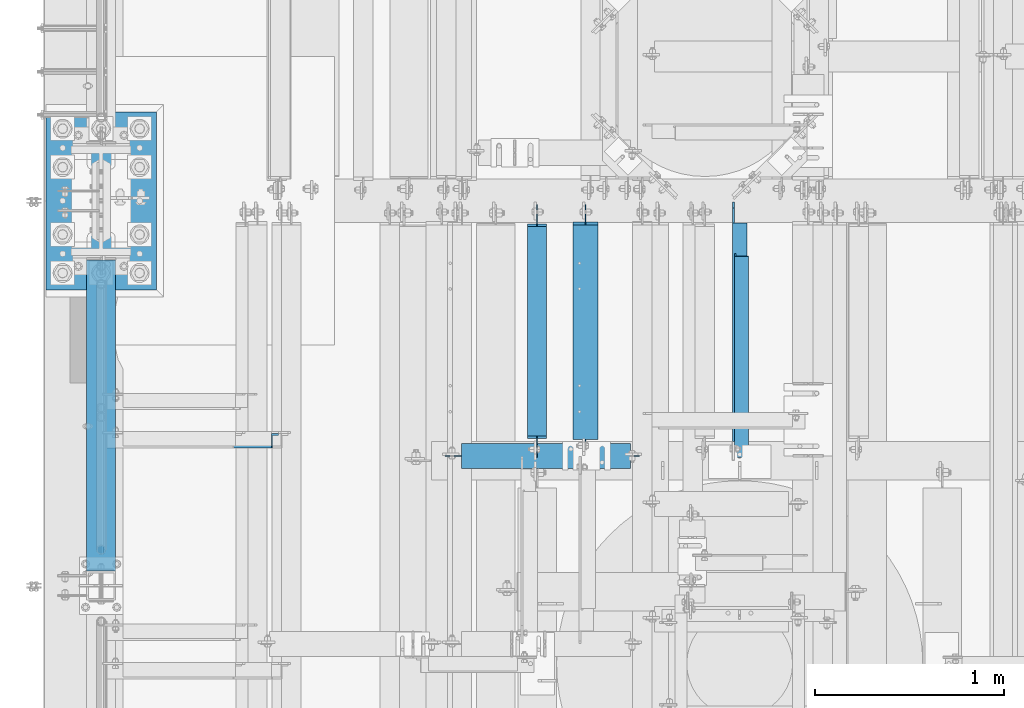
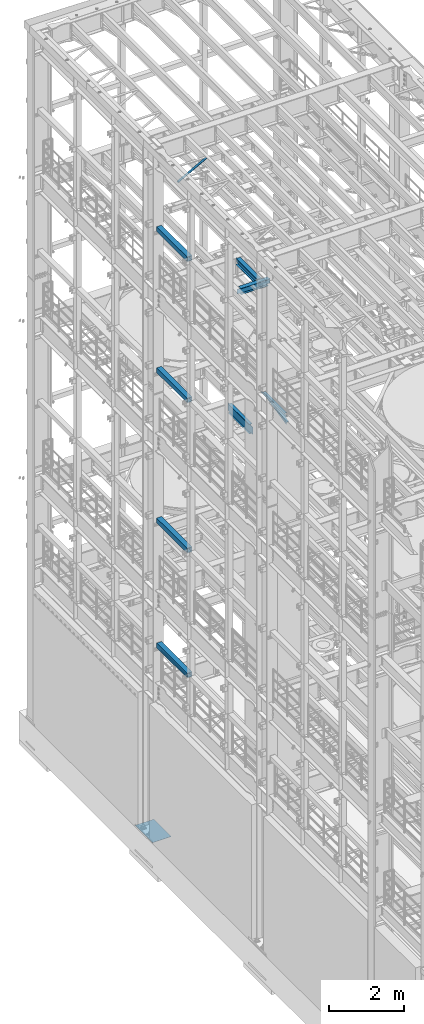
# One storey, part 1041 of 1876: 11 beams, 1 member, 12 elements without a shape of their own.
"""IFC2X3 building model written with IfcOpenShell, lengths in millimetres."""

from ifc_helpers import new_model, si_unit, frame, origin_with_axes, place, context, subcontext, project, spatial, faceted_brep, material, type_object, element, aggregate, save


model = new_model("IFC2X3")

# Units and contexts
model_context = context("Model", 3, precision=1e-05, world=origin_with_axes())
body_context = subcontext(model_context, "Body", "Model", "MODEL_VIEW")
ifc_project = project(units=[si_unit("LENGTHUNIT", "METRE", prefix="MILLI"), si_unit("AREAUNIT", "SQUARE_METRE"), si_unit("VOLUMEUNIT", "CUBIC_METRE"), si_unit("MASSUNIT", "GRAM", prefix="KILO"), si_unit("TIMEUNIT", "SECOND"), si_unit("PLANEANGLEUNIT", "RADIAN"), si_unit("SOLIDANGLEUNIT", "STERADIAN"), si_unit("THERMODYNAMICTEMPERATUREUNIT", "DEGREE_CELSIUS"), si_unit("LUMINOUSINTENSITYUNIT", "LUMEN")], contexts=[model_context])

# Site, building, storey
site_placement = place(None, origin_with_axes())
site = spatial("IfcSite", under=ifc_project, at=site_placement, CompositionType="ELEMENT")
building_placement = place(site_placement, origin_with_axes())
building = spatial("IfcBuilding", under=site, at=building_placement, Name="Undefined", CompositionType="ELEMENT")
storey_placement = place(building_placement, origin_with_axes())
storey = spatial("IfcBuildingStorey", under=building, at=storey_placement, Name="Undefined", CompositionType="ELEMENT", Elevation=0.0)

# Assembly, beam
assembly_1_placement = place(storey_placement, origin_with_axes())
assembly_1 = element("IfcElementAssembly", 1, at=assembly_1_placement, inside=storey, Name="RAIL", AssemblyPlace="NOTDEFINED", PredefinedType="RIGID_FRAME")
ifc_material_1 = material()
beam_type_1 = type_object("IfcBeamType", Name="PIPE1-1/2SCH40", PredefinedType="NOTDEFINED")
beam_1_placement = place(assembly_1_placement, frame((6.79847289575264e-10, 7204.0396633614, 6207.13724280096), z_axis=(0.0, 7.91400000045761e-06, -0.999999999968684), x_axis=(0.0, -0.999999999968684, -7.91400000071008e-06)))
beam_1 = element("IfcBeam", 2, at=beam_1_placement, type_object=beam_type_1, material=ifc_material_1, Name="RAIL", ObjectType="PIPE1-1/2SCH40", context=body_context, shape_type="Brep", body=[
    faceted_brep([(24.1297889306325, -20.4470000000001, 4.54747350886464e-12), (34.3533782626628, -17.7076214311801, 10.223500000001), (1416.58624781054, -17.7076214311801, 10.2235000002374), (1426.80965847928, -20.4470000000001, 2.42835085373372e-10), (41.8375650894295, -10.2235000000001, 17.7076214311801), (1409.10219177439, -10.2235000000001, 17.7076214314138), (44.5770000000002, 0.0, 20.4470000000001), (1406.3628371418, 0.0, 20.4470000002311), (41.8375650894295, 10.2235000000001, 17.7076214311801), (1409.10219177439, 10.2235000000001, 17.7076214314138), (34.3533782626628, 17.7076214311801, 10.223500000001), (1416.58624781054, 17.7076214311801, 10.2235000002374), (24.1297889306325, 20.4470000000001, 4.54747350886464e-12), (1426.80965847928, 20.4470000000001, 2.42835085373372e-10), (13.9061995986012, 17.7076214311801, -10.2234999999919), (1437.03306914802, 17.7076214311801, -10.2234999997499), (6.42201277183449, 10.2235000000001, -17.707621431171), (1444.51712518418, 10.2235000000001, -17.7076214309263), (3.68261026657001, 0.0, -20.4469999999901), (1447.25647981676, 0.0, -20.4469999997445), (6.42201277183449, -10.2235000000001, -17.707621431171), (1444.51712518418, -10.2235000000001, -17.7076214309263), (13.9061995986012, -17.7076214311801, -10.2234999999919), (1437.03306914802, -17.7076214311801, -10.2234999997499), (24.1297889306325, -24.1300000000001, 4.54747350886464e-12), (12.0646835077378, -20.8971929933186, -12.0649999999923), (1438.8745530573, -20.8971929933186, -12.0649999997486), (1426.80965847928, -24.1300000000001, 2.42835085373372e-10), (3.23241333950409, -12.0649999999996, -20.8971929933086), (1447.70666887637, -12.0649999999996, -20.8971929930613), (-0.000421915156039177, 0.0, -24.1299999999892), (1450.93944763532, 0.0, -24.1299999997409), (3.23241333950409, 12.0649999999996, -20.8971929933086), (1447.70666887637, 12.0649999999996, -20.8971929930613), (12.0646835077378, 20.8971929933186, -12.0649999999923), (1438.8745530573, 20.8971929933186, -12.0649999997486), (24.1297889306325, 24.1300000000001, 4.54747350886464e-12), (1426.80965847928, 24.1300000000001, 2.42835085373372e-10), (36.1948943535272, 20.8971929933186, 12.0650000000014), (1414.74476390127, 20.8971929933186, 12.0650000002352), (45.0271929933187, 12.0650000000001, 20.8971929933177), (1405.9126480822, 12.0649999999996, 20.8971929935497), (48.2600000000002, 0.0, 24.130000000001), (1402.67986932325, 0.0, 24.1300000002293), (45.0271929933187, -12.0650000000001, 20.8971929933177), (1405.9126480822, -12.0649999999996, 20.8971929935497), (36.1948943535263, -20.8971929933186, 12.0650000000014), (1414.74476390127, -20.8971929933186, 12.0650000002352)], [[[0, 1, 2, 3]], [[1, 4, 5, 2]], [[4, 6, 7, 5]], [[6, 8, 9, 7]], [[8, 10, 11, 9]], [[10, 12, 13, 11]], [[12, 14, 15, 13]], [[14, 16, 17, 15]], [[16, 18, 19, 17]], [[18, 20, 21, 19]], [[20, 22, 23, 21]], [[22, 0, 3, 23]], [[24, 25, 26, 27]], [[25, 28, 29, 26]], [[28, 30, 31, 29]], [[30, 32, 33, 31]], [[32, 34, 35, 33]], [[34, 36, 37, 35]], [[36, 38, 39, 37]], [[38, 40, 41, 39]], [[40, 42, 43, 41]], [[42, 44, 45, 43]], [[44, 46, 47, 45]], [[46, 24, 27, 47]], [[29, 31, 33, 35, 37, 39, 41, 43, 45, 47, 27, 26], [5, 7, 9, 11, 13, 15, 17, 19, 21, 23, 3, 2]], [[46, 44, 42, 40, 38, 36, 34, 32, 30, 28, 25, 24], [22, 20, 18, 16, 14, 12, 10, 8, 6, 4, 1, 0]]]),
])
aggregate(assembly_1, [beam_1])

assembly_2_placement = place(storey_placement, origin_with_axes())
assembly_2 = element("IfcElementAssembly", 3, at=assembly_2_placement, inside=storey, Name="BEAM", AssemblyPlace="NOTDEFINED", PredefinedType="RIGID_FRAME")
ifc_material_2 = material()
beam_type_2 = type_object("IfcBeamType", Name="HSS6X6X3/8", PredefinedType="NOTDEFINED")
beam_2_placement = place(assembly_2_placement, frame((0.0, 5588.0, 19958.05), z_axis=(-1.0, 0.0, 0.0), x_axis=(0.0, 1.0, 0.0)))
beam_2 = element("IfcBeam", 4, at=beam_2_placement, type_object=beam_type_2, material=ifc_material_2, Name="BEAM", ObjectType="HSS6X6X3/8", context=body_context, shape_type="Brep", body=[
    faceted_brep([(76.2000000000007, 66.6749999999993, -66.6750000000002), (76.2000000000007, -66.6749999999993, -66.6750000000002), (1720.85, -66.6749999999993, -66.675), (1720.85, 66.6749999999993, -66.675), (76.2000000000007, -66.6749999999993, 66.6750000000002), (1720.85, -66.6749999999993, 66.675), (76.2000000000007, 66.6749999999993, 66.6750000000002), (1720.85, 66.6749999999993, 66.675), (76.2000000000007, 76.2000000000007, -76.1999999999998), (76.2000000000007, 76.2000000000007, 76.1999999999998), (1720.85, 76.2000000000007, 76.2), (1720.85, 76.2000000000007, -76.2), (76.2000000000007, -76.2000000000007, 76.1999999999998), (1720.85, -76.2000000000007, 76.2), (76.2000000000007, -76.2000000000007, -76.1999999999998), (1720.85, -76.2000000000007, -76.2)], [[[0, 1, 2, 3]], [[1, 4, 5, 2]], [[4, 6, 7, 5]], [[6, 0, 3, 7]], [[8, 9, 10, 11]], [[9, 12, 13, 10]], [[12, 14, 15, 13]], [[14, 8, 11, 15]], [[13, 15, 11, 10], [5, 7, 3, 2]], [[14, 12, 9, 8], [6, 4, 1, 0]]]),
])
aggregate(assembly_2, [beam_2])

assembly_3_placement = place(storey_placement, origin_with_axes())
assembly_3 = element("IfcElementAssembly", 5, at=assembly_3_placement, inside=storey, Name="BEAM", AssemblyPlace="NOTDEFINED", PredefinedType="RIGID_FRAME")
beam_3_placement = place(assembly_3_placement, frame((0.0, 5588.0, 15335.25), z_axis=(-1.0, 0.0, 0.0), x_axis=(0.0, 1.0, 0.0)))
beam_3 = element("IfcBeam", 6, at=beam_3_placement, type_object=beam_type_2, material=ifc_material_2, Name="BEAM", ObjectType="HSS6X6X3/8", context=body_context, shape_type="Brep", body=[
    faceted_brep([(76.2000000000007, 66.6749999999993, -66.6750000000002), (76.2000000000007, -66.6749999999993, -66.6750000000002), (1720.85, -66.6749999999993, -66.675), (1720.85, 66.6749999999993, -66.675), (76.2000000000007, -66.6749999999993, 66.6750000000002), (1720.85, -66.6749999999993, 66.675), (76.2000000000007, 66.6749999999993, 66.6750000000002), (1720.85, 66.6749999999993, 66.675), (76.2000000000007, 76.2000000000007, -76.1999999999998), (76.2000000000007, 76.2000000000007, 76.1999999999998), (1720.85, 76.2000000000007, 76.2), (1720.85, 76.2000000000007, -76.2), (76.2000000000007, -76.2000000000007, 76.1999999999998), (1720.85, -76.2000000000007, 76.2), (76.2000000000007, -76.2000000000007, -76.1999999999998), (1720.85, -76.2000000000007, -76.2)], [[[0, 1, 2, 3]], [[1, 4, 5, 2]], [[4, 6, 7, 5]], [[6, 0, 3, 7]], [[8, 9, 10, 11]], [[9, 12, 13, 10]], [[12, 14, 15, 13]], [[14, 8, 11, 15]], [[13, 15, 11, 10], [5, 7, 3, 2]], [[14, 12, 9, 8], [6, 4, 1, 0]]]),
])
aggregate(assembly_3, [beam_3])

assembly_4_placement = place(storey_placement, origin_with_axes())
assembly_4 = element("IfcElementAssembly", 7, at=assembly_4_placement, inside=storey, Name="BEAM", AssemblyPlace="NOTDEFINED", PredefinedType="RIGID_FRAME")
beam_4_placement = place(assembly_4_placement, frame((0.0, 5588.0, 10420.35), z_axis=(-1.0, 0.0, 0.0), x_axis=(0.0, 1.0, 0.0)))
beam_4 = element("IfcBeam", 8, at=beam_4_placement, type_object=beam_type_2, material=ifc_material_2, Name="BEAM", ObjectType="HSS6X6X3/8", context=body_context, shape_type="Brep", body=[
    faceted_brep([(76.2000000000007, 66.6749999999993, -66.6750000000002), (76.2000000000007, -66.6749999999993, -66.6750000000002), (1720.85, -66.6749999999993, -66.675), (1720.85, 66.6749999999993, -66.675), (76.2000000000007, -66.6749999999993, 66.6750000000002), (1720.85, -66.6749999999993, 66.675), (76.2000000000007, 66.6749999999993, 66.6750000000002), (1720.85, 66.6749999999993, 66.675), (76.2000000000007, 76.2000000000007, -76.1999999999998), (76.2000000000007, 76.2000000000007, 76.1999999999998), (1720.85, 76.2000000000007, 76.2), (1720.85, 76.2000000000007, -76.2), (76.2000000000007, -76.2000000000007, 76.1999999999998), (1720.85, -76.2000000000007, 76.2), (76.2000000000007, -76.2000000000007, -76.1999999999998), (1720.85, -76.2000000000007, -76.2)], [[[0, 1, 2, 3]], [[1, 4, 5, 2]], [[4, 6, 7, 5]], [[6, 0, 3, 7]], [[8, 9, 10, 11]], [[9, 12, 13, 10]], [[12, 14, 15, 13]], [[14, 8, 11, 15]], [[13, 15, 11, 10], [5, 7, 3, 2]], [[14, 12, 9, 8], [6, 4, 1, 0]]]),
])
aggregate(assembly_4, [beam_4])

assembly_5_placement = place(storey_placement, origin_with_axes())
assembly_5 = element("IfcElementAssembly", 9, at=assembly_5_placement, inside=storey, Name="BEAM", AssemblyPlace="NOTDEFINED", PredefinedType="RIGID_FRAME")
beam_5_placement = place(assembly_5_placement, frame((0.0, 5588.0, 6330.95), z_axis=(-1.0, 0.0, 0.0), x_axis=(0.0, 1.0, 0.0)))
beam_5 = element("IfcBeam", 10, at=beam_5_placement, type_object=beam_type_2, material=ifc_material_2, Name="BEAM", ObjectType="HSS6X6X3/8", context=body_context, shape_type="Brep", body=[
    faceted_brep([(76.2000000000007, 66.6749999999993, -66.6750000000002), (76.2000000000007, -66.6749999999993, -66.6750000000002), (1720.85, -66.6749999999993, -66.675), (1720.85, 66.6749999999993, -66.675), (76.2000000000007, -66.6749999999993, 66.6750000000002), (1720.85, -66.6749999999993, 66.675), (76.2000000000007, 66.6749999999993, 66.6750000000002), (1720.85, 66.6749999999993, 66.675), (76.2000000000007, 76.2000000000007, -76.1999999999998), (76.2000000000007, 76.2000000000007, 76.1999999999998), (1720.85, 76.2000000000007, 76.2), (1720.85, 76.2000000000007, -76.2), (76.2000000000007, -76.2000000000007, 76.1999999999998), (1720.85, -76.2000000000007, 76.2), (76.2000000000007, -76.2000000000007, -76.1999999999998), (1720.85, -76.2000000000007, -76.2)], [[[0, 1, 2, 3]], [[1, 4, 5, 2]], [[4, 6, 7, 5]], [[6, 0, 3, 7]], [[8, 9, 10, 11]], [[9, 12, 13, 10]], [[12, 14, 15, 13]], [[14, 8, 11, 15]], [[13, 15, 11, 10], [5, 7, 3, 2]], [[14, 12, 9, 8], [6, 4, 1, 0]]]),
])
aggregate(assembly_5, [beam_5])

# Assembly, member
assembly_6_placement = place(storey_placement, origin_with_axes())
assembly_6 = element("IfcElementAssembly", 11, at=assembly_6_placement, inside=storey, AssemblyPlace="NOTDEFINED", PredefinedType="RIGID_FRAME")
ifc_material_3 = material(Name="STEEL/A36")
member_type = type_object("IfcMemberType", Name="L3X3X3/8", PredefinedType="NOTDEFINED")
member_placement = place(assembly_6_placement, frame((18.2754879686868, 6353.175, 22001.0692535961), z_axis=(0.0, -1.0, 0.0), x_axis=(0.877448093107104, 0.0, 0.479671600058526)))
member = element("IfcMember", 12, at=member_placement, type_object=member_type, material=ifc_material_3, ObjectType="L3X3X3/8", context=body_context, shape_type="Brep", body=[
    faceted_brep([(22.6152978728696, 38.0999999999985, -38.0999999999999), (22.6152978728696, 38.0999999999985, 38.0999999999999), (1025.78606203808, 38.1000000013628, 38.0999999999999), (1025.78606203808, 38.1000000013628, -38.0999999999999), (22.6152978728605, 28.5750000000044, 38.0999999999999), (1025.78606203807, 28.5750000013722, 38.0999999999999), (22.6152978728605, 28.5750000000044, -28.5749999999998), (1025.78606203807, 28.5750000013722, -28.5749999999998), (22.6152978728023, -38.0999999999367, -28.5749999999998), (1025.78606203801, -38.0999999985652, -28.5749999999998), (22.6152978728023, -38.0999999999367, -38.0999999999999), (1025.78606203801, -38.0999999985652, -38.0999999999999)], [[[0, 1, 2, 3]], [[1, 4, 5, 2]], [[4, 6, 7, 5]], [[6, 8, 9, 7]], [[8, 10, 11, 9]], [[10, 0, 3, 11]], [[5, 7, 9, 11, 3, 2]], [[10, 8, 6, 4, 1, 0]]]),
])
aggregate(assembly_6, [member])

# Assembly, beam
assembly_7_placement = place(storey_placement, origin_with_axes())
assembly_7 = element("IfcElementAssembly", 13, at=assembly_7_placement, inside=storey, AssemblyPlace="NOTDEFINED", PredefinedType="RIGID_FRAME")
beam_type_3 = type_object("IfcBeamType", Name="L3X3X3/8", PredefinedType="NOTDEFINED")
beam_6_placement = place(assembly_7_placement, frame((3381.37461036534, 6246.81249999999, 13023.8500000001), z_axis=(1.0, 0.0, 0.0), x_axis=(0.0, 0.979027474402913, 0.203728261083863)))
beam_6 = element("IfcBeam", 14, at=beam_6_placement, type_object=beam_type_3, material=ifc_material_3, ObjectType="L3X3X3/8", context=body_context, shape_type="Brep", body=[
    faceted_brep([(24.9541482593741, 38.0999999999894, -38.0999999999999), (24.9541482593741, 38.0999999999894, 38.0999999999999), (1110.4205780976, 38.0999999997621, 38.0999999999999), (1110.4205780976, 38.0999999997621, -38.0999999999999), (24.9541482593759, 28.5749999999916, 38.0999999999999), (1110.4205780976, 28.5749999997643, 38.0999999999999), (24.9541482593759, 28.5749999999916, -28.5749999999998), (1110.4205780976, 28.5749999997643, -28.5749999999998), (24.9541482593741, -38.0999999999967, -28.5749999999998), (1110.4205780976, -38.1000000002205, -28.5749999999998), (24.9541482593741, -38.0999999999967, -38.0999999999999), (1110.4205780976, -38.1000000002205, -38.0999999999999)], [[[0, 1, 2, 3]], [[1, 4, 5, 2]], [[4, 6, 7, 5]], [[6, 8, 9, 7]], [[8, 10, 11, 9]], [[10, 0, 3, 11]], [[5, 7, 9, 11, 3, 2]], [[10, 8, 6, 4, 1, 0]]]),
])
aggregate(assembly_7, [beam_6])

assembly_8_placement = place(storey_placement, origin_with_axes())
assembly_8 = element("IfcElementAssembly", 15, at=assembly_8_placement, inside=storey, Name="ANGLE", AssemblyPlace="NOTDEFINED", PredefinedType="RIGID_FRAME")
beam_7_placement = place(assembly_8_placement, frame((3371.84961036534, 6246.8125, 13271.5), z_axis=(1.0, 0.0, 0.0), x_axis=(0.0, 1.0, 0.0)))
beam_7 = element("IfcBeam", 16, at=beam_7_placement, type_object=beam_type_3, material=ifc_material_3, Name="ANGLE", ObjectType="L3X3X3/8", context=body_context, shape_type="Brep", body=[
    faceted_brep([(103.186999799132, 38.1000000000004, 38.0999999999999), (103.186999799132, 28.5750000000007, 38.0999999999999), (1257.30050116882, 28.5750000000007, 38.0999999999999), (1257.30050116881, 38.1000000000004, 38.0999999999999), (103.186998865692, 28.5750000000007, -28.5749999999998), (1257.30050030205, 28.5750000000007, -28.5749999999998), (1334.29374828785, 12.6999992370602, -28.5749999999998), (1334.29374816402, 12.6999992370602, -38.0999999999999), (1257.3005001782, 12.6999992370602, -38.0999999999999), (1257.30050030203, 12.6999992370602, -28.5749999999998), (1257.30050017822, 38.1000000000004, -38.0999999999999), (103.186998732343, 38.1000000000004, -38.0999999999999), (103.186998732343, 22.2250007629391, -38.0999999999999), (103.186998865692, 22.2250007629391, -28.5749999999998), (29.3687518909128, 22.2250007629391, -38.0999999999999), (29.3687520242611, 22.2250007629391, -28.5749999999998), (3.96875227238252, -3.17500076293982, -38.0999999999999), (3.96875240573081, -3.17500076293982, -28.5749999999998), (3.96875000000273, -38.1000000000004, -38.0999999999999), (3.96875000000273, -38.1000000000004, -28.5749999999998), (1366.04375, -38.1000000000004, -28.5749999999998), (1366.04374828785, -19.0500007629398, -28.5749999999998), (1366.04374816402, -19.0500007629398, -38.0999999999999), (1366.04375, -38.1000000000004, -38.0999999999999)], [[[0, 1, 2, 3]], [[1, 4, 5, 2]], [[6, 7, 8, 9]], [[2, 5, 9, 8, 10, 3]], [[11, 0, 3, 10]], [[1, 0, 11, 12, 13, 4]], [[13, 12, 14, 15]], [[15, 14, 16, 17]], [[16, 18, 19, 17]], [[6, 9, 5, 4, 13, 15, 17, 19, 20, 21]], [[7, 6, 21, 22]], [[18, 16, 14, 12, 11, 10, 8, 7, 22, 23]], [[19, 18, 23, 20]], [[22, 21, 20, 23]]]),
])
aggregate(assembly_8, [beam_7])

assembly_9_placement = place(storey_placement, origin_with_axes())
assembly_9 = element("IfcElementAssembly", 17, at=assembly_9_placement, inside=storey, Name="BEAM", AssemblyPlace="NOTDEFINED", PredefinedType="RIGID_FRAME")
ifc_material_4 = material(Name="STEEL/A992")
beam_type_4 = type_object("IfcBeamType", Name="W12X16", PredefinedType="NOTDEFINED")
beam_8_placement = place(assembly_9_placement, frame((2301.875, 6115.05, 13157.2), z_axis=(0.0, 0.0, 1.0), x_axis=(0.0, 1.0, 0.0)))
beam_8 = element("IfcBeam", 18, at=beam_8_placement, type_object=beam_type_4, material=ifc_material_4, Name="BEAM", ObjectType="W12X16", context=body_context, shape_type="Brep", body=[
    faceted_brep([(148.431250000001, -3.17500000000018, -127.0), (148.431250000001, 3.17500000000018, -127.0), (237.331250190735, 3.17500000000018, -127.0), (237.331250190735, -3.17500000000018, -127.0), (242.19132970878, 3.17500000000018, -127.966729922588), (242.19132970878, -3.17500000000018, -127.966729922588), (246.311506176934, 3.17500000000018, -130.719743823067), (246.311506176934, -3.17500000000018, -130.719743823067), (249.064520077412, 3.17500000000018, -134.839920291221), (249.064520077412, -3.17500000000018, -134.839920291221), (250.03125, -3.17500000000018, -139.699999809265), (250.03125, 3.17500000000018, -139.699999809265), (250.031249999999, 3.17500000000018, -146.049999999999), (250.031249999999, 50.8000000000002, -146.049999999999), (250.031249999999, 50.8000000000002, -152.4), (250.031249999999, -50.8000000000002, -152.4), (250.031249999999, -50.8000000000002, -146.049999999999), (250.031249999999, -3.17500000000018, -146.049999999999), (1370.80625, 50.8000000000002, 146.049999999999), (1370.80625, 3.17500000000018, 146.049999999999), (262.73125, 3.17500000000018, 146.049999999999), (262.73125, 50.8000000000002, 146.049999999999), (250.031250190735, -3.17500000000018, 107.950000000001), (250.031250190735, 3.17500000000018, 107.950000000001), (148.431250000001, 3.17500000000018, 107.950000000001), (148.431250000001, -3.17500000000018, 107.950000000001), (254.89132970878, -3.17500000000018, 108.916729922588), (254.89132970878, 3.17500000000018, 108.916729922588), (259.011506176934, -3.17500000000018, 111.669743823066), (259.011506176934, 3.17500000000018, 111.669743823066), (261.764520077412, -3.17500000000018, 115.789920291219), (261.764520077412, 3.17500000000018, 115.789920291219), (262.73125, -3.17500000000018, 120.649999809266), (262.73125, 3.17500000000018, 120.649999809266), (1370.80625, -50.8000000000002, 152.4), (1370.80625, 50.8000000000002, 152.4), (262.73125, 50.8000000000002, 152.4), (262.73125, -50.8000000000002, 152.4), (1370.80625, -50.8000000000002, 146.049999999999), (262.73125, -50.8000000000002, 146.049999999999), (1370.80625, -3.17500000000018, 146.049999999999), (262.73125, -3.17500000000018, 146.049999999999), (1370.80625, -3.17500000000018, 126.999999809264), (1370.80625, 3.17500000000018, 126.999999809264), (1371.77297992259, -3.17500000000018, 122.139920291218), (1371.77297992259, 3.17500000000018, 122.139920291218), (1374.52599382306, -3.17500000000018, 118.019743823064), (1374.52599382306, 3.17500000000018, 118.019743823064), (1378.64617029122, -3.17500000000018, 115.266729922587), (1378.64617029122, 3.17500000000018, 115.266729922587), (1383.50624980926, -3.17500000000018, 114.299999999999), (1383.50624980926, 3.17500000000018, 114.299999999999), (1485.10625, -3.17500000000018, 114.299999999999), (1485.10625, 3.17500000000018, 114.299999999999), (1485.10625, -3.17500000000018, -127.0), (1485.10625, 3.17500000000018, -127.0), (1396.20624980926, -3.17500000000018, -127.0), (1396.20624980926, 3.17500000000018, -127.0), (1391.34617029122, -3.17500000000018, -127.966729922588), (1391.34617029122, 3.17500000000018, -127.966729922588), (1387.22599382306, -3.17500000000018, -130.719743823065), (1387.22599382306, 3.17500000000018, -130.719743823065), (1384.47297992259, -3.17500000000018, -134.839920291219), (1384.47297992259, 3.17500000000018, -134.839920291219), (1383.50625, -3.17500000000018, -139.699999809265), (1383.50625, 3.17500000000018, -139.699999809265), (1383.50625, -3.17500000000018, -146.049999999999), (1383.50625, -50.8000000000002, -146.049999999999), (1383.50625, -50.8000000000002, -152.4), (1383.50625, 50.8000000000002, -152.4), (1383.50625, 50.8000000000002, -146.049999999999), (1383.50625, 3.17500000000018, -146.049999999999)], [[[0, 1, 2, 3]], [[3, 2, 4, 5]], [[5, 4, 6, 7]], [[7, 6, 8, 9]], [[10, 11, 12, 13, 14, 15, 16, 17]], [[9, 8, 11, 10]], [[18, 19, 20, 21]], [[22, 23, 24, 25]], [[26, 27, 23, 22]], [[28, 29, 27, 26]], [[30, 31, 29, 28]], [[32, 33, 31, 30]], [[34, 35, 36, 37]], [[38, 34, 37, 39]], [[40, 38, 39, 41]], [[37, 36, 21, 20, 33, 32, 41, 39]], [[35, 18, 21, 36]], [[34, 38, 40, 42, 43, 19, 18, 35]], [[44, 45, 43, 42]], [[46, 47, 45, 44]], [[48, 49, 47, 46]], [[50, 51, 49, 48]], [[52, 53, 51, 50]], [[53, 52, 54, 55]], [[54, 56, 57, 55]], [[58, 59, 57, 56]], [[60, 61, 59, 58]], [[62, 63, 61, 60]], [[64, 65, 63, 62]], [[66, 67, 68, 69, 70, 71, 65, 64]], [[67, 66, 17, 16]], [[68, 67, 16, 15]], [[69, 68, 15, 14]], [[70, 69, 14, 13]], [[71, 70, 13, 12]], [[6, 4, 2, 1, 24, 23, 27, 29, 31, 33, 20, 19, 43, 45, 47, 49, 51, 53, 55, 57, 59, 61, 63, 65, 71, 12, 11, 8]], [[25, 24, 1, 0]], [[66, 64, 62, 60, 58, 56, 54, 52, 50, 48, 46, 44, 42, 40, 41, 32, 30, 28, 26, 22, 25, 0, 3, 5, 7, 9, 10, 17]]]),
])
aggregate(assembly_9, [beam_8])

assembly_10_placement = place(storey_placement, origin_with_axes())
assembly_10 = element("IfcElementAssembly", 19, at=assembly_10_placement, inside=storey, Name="BEAM", AssemblyPlace="NOTDEFINED", PredefinedType="RIGID_FRAME")
beam_type_5 = type_object("IfcBeamType", Name="W8X18", PredefinedType="NOTDEFINED")
beam_9_placement = place(assembly_10_placement, frame((2557.52483848424, 7620.0, 17880.0125), z_axis=(0.0, 0.0, 1.0), x_axis=(4.46050000005016e-05, -0.999999999005197, 0.0)))
beam_9 = element("IfcBeam", 20, at=beam_9_placement, type_object=beam_type_5, material=ifc_material_4, Name="BEAM", ObjectType="W8X18", context=body_context, shape_type="Brep", body=[
    faceted_brep([(19.8436083988572, -3.17500000000155, -80.9624999999942), (19.8438916406067, 3.17499999999745, -80.9624999999942), (99.2217242490597, 3.17499999998563, -80.9624999999942), (99.2217242490588, -3.17500000001291, -80.9624999999942), (104.081803767102, 3.17499999998472, -81.9292299225817), (104.081803767102, -3.17500000001337, -81.9292299225817), (108.201980235253, 3.17499999998427, -84.6822438230593), (108.201980235253, -3.17500000001473, -84.6822438230593), (110.954994135731, 3.17499999998427, -88.8024202912129), (110.954994135729, -3.17500000001473, -88.8024202912129), (111.921724058317, -3.17500000001519, -93.6624998092593), (111.921724058317, 3.17499999998427, -93.6624998092593), (111.921724058317, 3.17499999998427, -95.25), (111.921724058326, 66.674999999972, -95.25), (111.921724058326, 66.674999999972, -103.1875), (111.921724058308, -66.6750000000034, -103.1875), (111.921724058308, -66.6750000000034, -95.25), (111.921724058317, -3.17500000001519, -95.25), (1261.09533661012, 66.6749999998078, 95.25), (1261.09533661011, 3.17499999981919, 95.25), (127.796724058297, 3.17499999998154, 95.25), (127.796724058305, 66.6749999999702, 95.25), (115.096724249037, -3.17500000001519, 65.0875000000051), (115.096724249039, 3.17499999998336, 65.0875000000051), (19.8438916406067, 3.17499999999745, 65.0875000000051), (19.8436083988572, -3.17500000000155, 65.0875000000051), (119.956803767081, -3.1750000000161, 66.0542299225926), (119.956803767082, 3.1749999999829, 66.0542299225926), (124.076980235232, -3.17500000001655, 68.8072438230702), (124.076980235232, 3.17499999998199, 68.8072438230702), (126.829994135707, -3.17500000001701, 72.9274202912238), (126.82999413571, 3.17499999998154, 72.9274202912238), (127.796724058296, -3.17500000001746, 77.7874998092702), (127.796724058297, 3.17499999998154, 77.7874998092702), (1261.0953366101, -66.6750000001675, 103.1875), (1261.09533661012, 66.6749999998078, 103.1875), (127.796724058305, 66.6749999999702, 103.1875), (127.796724058287, -66.6750000000056, 103.1875), (1261.0953366101, -66.6750000001675, 95.25), (127.796724058287, -66.6750000000056, 95.25), (1261.09533661011, -3.1750000001789, 95.25), (127.796724058295, -3.17500000001746, 95.25), (1261.09533661011, -3.1750000001789, 90.4874998092637), (1261.09533661011, 3.17499999981919, 90.4874998092637), (1262.0620665327, -3.17500000017935, 85.6274202912173), (1262.0620665327, 3.17499999981965, 85.6274202912173), (1264.81508043317, -3.17500000017981, 81.5072438230636), (1264.81508043317, 3.17499999981874, 81.5072438230636), (1268.93525690132, -3.17500000018026, 78.7542299225861), (1268.93525690132, 3.17499999981828, 78.7542299225861), (1273.79533641937, -3.17500000018117, 77.7874999999985), (1273.79533641937, 3.17499999981783, 77.7874999999985), (1330.94816902883, -3.17500000018936, 77.7874999999985), (1330.94845227058, 3.17499999980964, 77.7874999999985), (1330.94816902883, -3.17500000018936, -77.7875000000022), (1330.94845227058, 3.17499999980964, -77.7875000000022), (1251.5703364194, -3.17500000017753, -77.7875000000022), (1251.5703364194, 3.17499999982056, -77.7875000000022), (1246.71025690135, -3.17500000017708, -78.7542299225897), (1246.71025690135, 3.17499999982147, -78.7542299225897), (1242.5900804332, -3.17500000017617, -81.5072438230673), (1242.5900804332, 3.17499999982192, -81.5072438230673), (1239.83706653272, -3.17500000017617, -85.6274202912209), (1239.83706653273, 3.17499999982283, -85.6274202912209), (1238.87033661014, -3.17500000017617, -90.4874998092673), (1238.87033661014, 3.17499999982283, -90.4874998092673), (1238.87033661014, -3.17500000017617, -95.25), (1238.87033661013, -66.6750000001648, -95.25), (1238.87033661013, -66.6750000001648, -103.1875), (1238.87033661015, 66.674999999811, -103.1875), (1238.87033661015, 66.674999999811, -95.25), (1238.87033661014, 3.17499999982283, -95.25)], [[[0, 1, 2, 3]], [[3, 2, 4, 5]], [[5, 4, 6, 7]], [[7, 6, 8, 9]], [[10, 11, 12, 13, 14, 15, 16, 17]], [[9, 8, 11, 10]], [[18, 19, 20, 21]], [[22, 23, 24, 25]], [[26, 27, 23, 22]], [[28, 29, 27, 26]], [[30, 31, 29, 28]], [[32, 33, 31, 30]], [[34, 35, 36, 37]], [[38, 34, 37, 39]], [[40, 38, 39, 41]], [[37, 36, 21, 20, 33, 32, 41, 39]], [[35, 18, 21, 36]], [[34, 38, 40, 42, 43, 19, 18, 35]], [[44, 45, 43, 42]], [[46, 47, 45, 44]], [[48, 49, 47, 46]], [[50, 51, 49, 48]], [[52, 53, 51, 50]], [[53, 52, 54, 55]], [[54, 56, 57, 55]], [[58, 59, 57, 56]], [[60, 61, 59, 58]], [[62, 63, 61, 60]], [[64, 65, 63, 62]], [[66, 67, 68, 69, 70, 71, 65, 64]], [[67, 66, 17, 16]], [[68, 67, 16, 15]], [[69, 68, 15, 14]], [[70, 69, 14, 13]], [[71, 70, 13, 12]], [[6, 4, 2, 1, 24, 23, 27, 29, 31, 33, 20, 19, 43, 45, 47, 49, 51, 53, 55, 57, 59, 61, 63, 65, 71, 12, 11, 8]], [[25, 24, 1, 0]], [[66, 64, 62, 60, 58, 56, 54, 52, 50, 48, 46, 44, 42, 40, 41, 32, 30, 28, 26, 22, 25, 0, 3, 5, 7, 9, 10, 17]]]),
])
aggregate(assembly_10, [beam_9])

assembly_11_placement = place(storey_placement, origin_with_axes())
assembly_11 = element("IfcElementAssembly", 21, at=assembly_11_placement, inside=storey, Name="BEAM", AssemblyPlace="NOTDEFINED", PredefinedType="RIGID_FRAME")
beam_10_placement = place(assembly_11_placement, frame((1798.6375, 6273.17669067383, 17880.0125), z_axis=(0.0, 0.0, 1.0), x_axis=(1.0, 0.0, 0.0)))
beam_10 = element("IfcBeam", 22, at=beam_10_placement, type_object=beam_type_5, material=ifc_material_4, Name="BEAM", ObjectType="W8X18", context=body_context, shape_type="Brep", body=[
    faceted_brep([(15.875, -3.17500000000018, -84.1375000000007), (15.875, 3.17500000000018, -84.1375000000007), (92.075000190735, 3.17500002374254, -84.1375000000007), (92.075000190735, -3.17500000000018, -84.1375000000007), (96.9350797087804, 3.17500002397628, -85.1042299225883), (96.9350797087804, -3.17500000000018, -85.1042299225883), (101.055256176934, 3.17500002463203, -87.8572438230658), (101.055256176934, -3.17500000000018, -87.8572438230658), (103.808270077412, 3.17500002560791, -91.9774202912195), (103.808270077412, -3.17500000000018, -91.9774202912195), (104.775, -66.6750000000002, -96.8374998092659), (104.775, 66.6750000000002, -96.8374998092659), (104.775000000001, 66.6750000000002, -103.1875), (104.775000000001, -66.6750000000002, -103.1875), (104.459226654724, -66.6750000000002, -95.25), (104.459226654724, -3.17500000000018, -95.25), (104.459226654724, 3.17500009399282, -95.25), (104.459226654724, 66.6750000000002, -95.25), (995.362500000001, -66.6750000000002, 103.1875), (995.362500000001, 66.6750000000002, 103.1875), (104.775, 66.6750000000002, 103.1875), (104.775, -66.6750000000002, 103.1875), (995.678273345278, -66.6750000000002, 95.25), (995.362500000001, -66.6750000000002, 96.8374998092695), (104.775, -66.6750000000002, 95.25), (995.362500000001, 66.6750000000002, 96.8374998092695), (995.678273345278, 66.6750000000002, 95.25), (104.775, 66.6750000000002, 95.25), (995.678273345278, 3.17500000000018, 95.25), (104.775, 3.17500000000018, 95.25), (92.075000190735, -3.17500000000018, 71.4375), (92.075000190735, 3.17499998808489, 71.4375), (15.875, 3.17500000000018, 71.4375), (15.875, -3.17500000000018, 71.4375), (96.9350797087804, -3.17500000000018, 72.4042299225875), (96.9350797087804, 3.17499998786025, 72.4042299225875), (101.055256176934, -3.17500000000018, 75.1572438230651), (101.055256176934, 3.17499998721905, 75.1572438230651), (103.808270077412, -3.17500000000018, 79.2774202912187), (103.808270077412, 3.17499998625863, 79.2774202912187), (104.775, -3.17500000000018, 84.1374998092651), (104.775, 3.17499998512449, 84.1374998092651), (104.775, -3.17500000000018, 95.25), (995.678273345278, -3.17500000000018, 95.25), (996.329229922589, -3.17500000000018, 91.9774202912231), (996.329229922589, 3.17500000000018, 91.9774202912231), (999.082243823067, -3.17500000000018, 87.8572438230694), (999.082243823067, 3.17500000000018, 87.8572438230694), (1003.20242029122, -3.17500000000018, 85.1042299225919), (1003.20242029122, 3.17500000000018, 85.1042299225919), (1008.06249980927, -3.17500000000018, 84.1375000000044), (1008.06249980927, 3.17500000000018, 84.1375000000044), (1042.9875, -3.17500000000018, 84.1375000000044), (1042.9875, 3.17500000000018, 84.1375000000044), (1042.9875, -3.17500000000018, -77.7874999999949), (1042.9875, 3.17500000000018, -77.7874999999949), (963.612499809266, -3.17500000000018, -77.7874999999949), (963.612499809266, 3.17500000000018, -77.7874999999949), (958.75242029122, -3.17500000000018, -78.7542299225825), (958.75242029122, 3.17500000000018, -78.7542299225825), (954.632243823067, -3.17500000000018, -81.50724382306), (954.632243823067, 3.17500000000018, -81.50724382306), (951.879229922588, -3.17500000000018, -85.6274202912136), (951.879229922588, 3.17500000000018, -85.6274202912136), (950.912500000001, -3.17500000000018, -90.48749980926), (950.912500000001, 3.17500000000018, -90.48749980926), (950.912500000001, -3.17500000000018, -95.25), (950.912500000001, -66.6750000000002, -95.25), (950.912500000001, -66.6750000000002, -103.1875), (950.912500000001, 66.6750000000002, -103.1875), (950.912500000001, 66.6750000000002, -95.25), (950.912500000001, 3.17500000000018, -95.25)], [[[0, 1, 2, 3]], [[3, 2, 4, 5]], [[5, 4, 6, 7]], [[7, 6, 8, 9]], [[10, 11, 12, 13]], [[14, 15, 9, 8, 16, 17, 11, 10]], [[18, 19, 20, 21]], [[22, 23, 18, 21, 24]], [[18, 23, 25, 19]], [[19, 25, 26, 27, 20]], [[26, 28, 29, 27]], [[30, 31, 32, 33]], [[34, 35, 31, 30]], [[36, 37, 35, 34]], [[38, 39, 37, 36]], [[40, 41, 39, 38]], [[21, 20, 27, 29, 41, 40, 42, 24]], [[43, 22, 24, 42]], [[44, 45, 28, 26, 25, 23, 22, 43]], [[46, 47, 45, 44]], [[48, 49, 47, 46]], [[50, 51, 49, 48]], [[52, 53, 51, 50]], [[53, 52, 54, 55]], [[54, 56, 57, 55]], [[58, 59, 57, 56]], [[60, 61, 59, 58]], [[62, 63, 61, 60]], [[64, 65, 63, 62]], [[66, 67, 68, 69, 70, 71, 65, 64]], [[69, 68, 13, 12]], [[70, 69, 12, 11, 17]], [[71, 70, 17, 16]], [[6, 4, 2, 1, 32, 31, 35, 37, 39, 41, 29, 28, 45, 47, 49, 51, 53, 55, 57, 59, 61, 63, 65, 71, 16, 8]], [[33, 32, 1, 0]], [[66, 64, 62, 60, 58, 56, 54, 52, 50, 48, 46, 44, 43, 42, 40, 38, 36, 34, 30, 33, 0, 3, 5, 7, 9, 15]], [[67, 66, 15, 14]], [[68, 67, 14, 10, 13]]]),
])
aggregate(assembly_11, [beam_10])

assembly_12_placement = place(storey_placement, origin_with_axes())
assembly_12 = element("IfcElementAssembly", 23, at=assembly_12_placement, inside=storey, Name="TEMPLATE", AssemblyPlace="NOTDEFINED", PredefinedType="RIGID_FRAME")
beam_type_6 = type_object("IfcBeamType", PredefinedType="NOTDEFINED")
beam_11_placement = place(assembly_12_placement, frame((0.0, 7150.1, 40.4814999999999), z_axis=(-1.0, 0.0, 0.0), x_axis=(0.0, 1.0, 0.0)))
beam_11 = element("IfcBeam", 24, at=beam_11_placement, type_object=beam_type_6, material=ifc_material_3, Name="TEMPLATE", context=body_context, shape_type="Brep", body=[
    faceted_brep([(0.0, 2.3815, -292.1), (0.0, 2.3815, 292.1), (939.8, 2.3815, 292.1), (939.8, 2.3815, -292.1), (0.0, -2.3815, 292.1), (939.8, -2.3815, 292.1), (0.0, -2.3815, -292.1), (939.8, -2.3815, -292.1)], [[[0, 1, 2, 3]], [[1, 4, 5, 2]], [[4, 6, 7, 5]], [[6, 0, 3, 7]], [[5, 7, 3, 2]], [[6, 4, 1, 0]]]),
])
aggregate(assembly_12, [beam_11])

save(model, "model.ifc")
